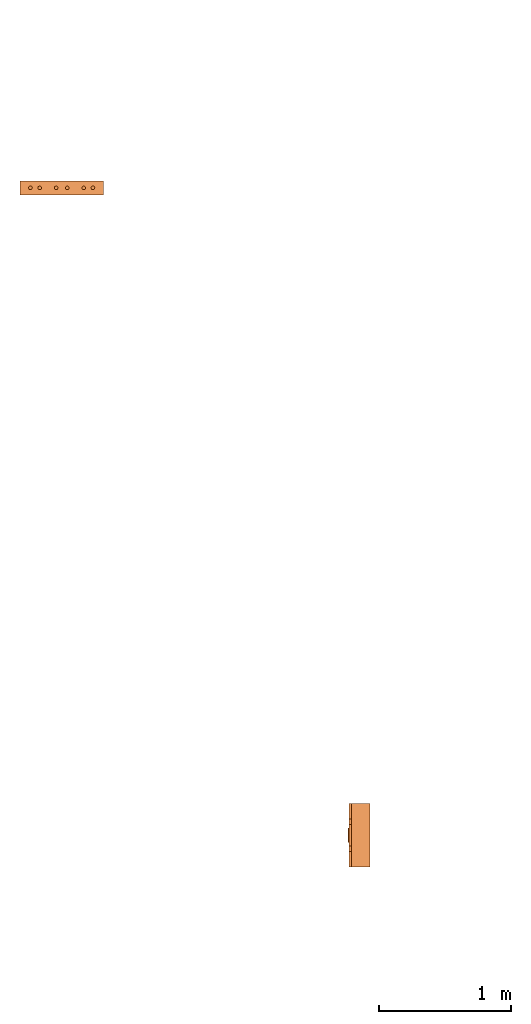
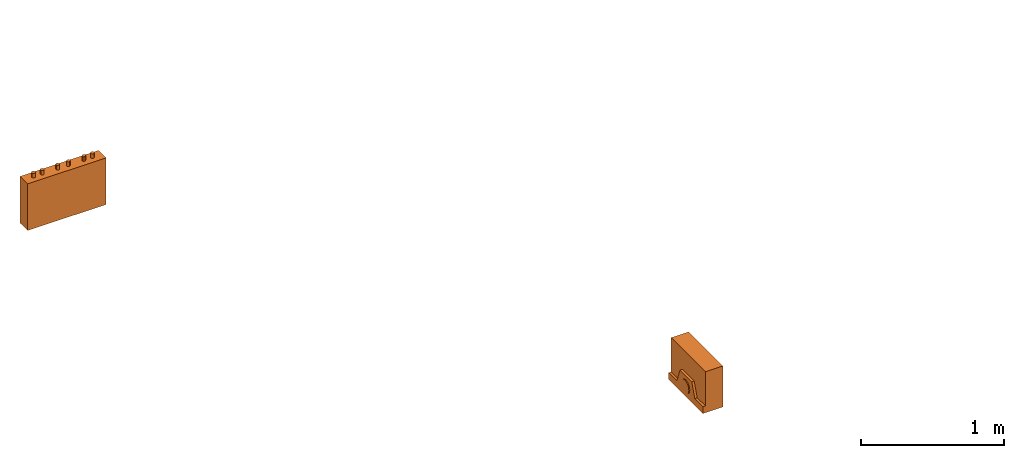
# One storey, part 1 of 3: 2 proxies.
"""IFC2X3 building model written with IfcOpenShell, lengths in millimetres."""

from ifc_helpers import new_model, entity, si_unit, converted_unit, derived_unit, direction, frame, origin, place, context, subcontext, project, spatial, faceted_brep, source, transform, mapped, material, material_list, type_object, type_shapes, element, save


model = new_model("IFC2X3")

# Units and contexts
model_context = context("Model", 3, precision=0.01, world=origin(), true_north=direction((6.12303176911189e-17, 1.0)))
body_context = subcontext(model_context, "Body", "Model", "MODEL_VIEW")
ifc_project = project(units=[si_unit("LENGTHUNIT", "METRE", prefix="MILLI"), si_unit("AREAUNIT", "SQUARE_METRE"), si_unit("VOLUMEUNIT", "CUBIC_METRE"), converted_unit("PLANEANGLEUNIT", "DEGREE", entity("IfcRatioMeasure", 0.0174532925199433), si_unit("PLANEANGLEUNIT", "RADIAN"), dimensions=[0, 0, 0, 0, 0, 0, 0]), si_unit("MASSUNIT", "GRAM", prefix="KILO"), derived_unit("MASSDENSITYUNIT", [(si_unit("MASSUNIT", "GRAM", prefix="KILO"), 1), (si_unit("LENGTHUNIT", "METRE"), -3)]), derived_unit("MOMENTOFINERTIAUNIT", [(si_unit("LENGTHUNIT", "METRE"), 4)]), si_unit("TIMEUNIT", "SECOND"), si_unit("FREQUENCYUNIT", "HERTZ"), si_unit("THERMODYNAMICTEMPERATUREUNIT", "DEGREE_CELSIUS"), derived_unit("THERMALTRANSMITTANCEUNIT", [(si_unit("MASSUNIT", "GRAM", prefix="KILO"), 1), (si_unit("THERMODYNAMICTEMPERATUREUNIT", "KELVIN"), -1), (si_unit("TIMEUNIT", "SECOND"), -3)]), derived_unit("VOLUMETRICFLOWRATEUNIT", [(si_unit("LENGTHUNIT", "METRE"), 3), (si_unit("TIMEUNIT", "SECOND"), -1)]), derived_unit("MASSFLOWRATEUNIT", [(si_unit("MASSUNIT", "GRAM", prefix="KILO"), 1), (si_unit("TIMEUNIT", "SECOND"), -1)]), derived_unit("ROTATIONALFREQUENCYUNIT", [(si_unit("TIMEUNIT", "SECOND"), -1)]), si_unit("ELECTRICCURRENTUNIT", "AMPERE"), si_unit("ELECTRICVOLTAGEUNIT", "VOLT"), si_unit("POWERUNIT", "WATT"), si_unit("FORCEUNIT", "NEWTON", prefix="KILO"), si_unit("ILLUMINANCEUNIT", "LUX"), si_unit("LUMINOUSFLUXUNIT", "LUMEN"), si_unit("LUMINOUSINTENSITYUNIT", "CANDELA"), derived_unit("USERDEFINED", [(si_unit("MASSUNIT", "GRAM", prefix="KILO"), -1), (si_unit("LENGTHUNIT", "METRE"), -2), (si_unit("TIMEUNIT", "SECOND"), 3), (si_unit("LUMINOUSFLUXUNIT", "LUMEN"), 1)]), derived_unit("LINEARVELOCITYUNIT", [(si_unit("LENGTHUNIT", "METRE"), 1), (si_unit("TIMEUNIT", "SECOND"), -1)]), si_unit("PRESSUREUNIT", "PASCAL"), derived_unit("USERDEFINED", [(si_unit("LENGTHUNIT", "METRE"), -2), (si_unit("MASSUNIT", "GRAM", prefix="KILO"), 1), (si_unit("TIMEUNIT", "SECOND"), -2)]), derived_unit("LINEARFORCEUNIT", [(si_unit("MASSUNIT", "GRAM", prefix="KILO"), 1), (si_unit("LENGTHUNIT", "METRE"), 1), (si_unit("TIMEUNIT", "SECOND"), -2), (si_unit("LENGTHUNIT", "METRE"), -1)]), derived_unit("PLANARFORCEUNIT", [(si_unit("MASSUNIT", "GRAM", prefix="KILO"), 1), (si_unit("LENGTHUNIT", "METRE"), 1), (si_unit("TIMEUNIT", "SECOND"), -2), (si_unit("LENGTHUNIT", "METRE"), -2)])], contexts=[model_context])

# Site, building, storey
site_placement = place(None, frame((0.0, 2493.83037508239, 0.0)))
site = spatial("IfcSite", under=ifc_project, at=site_placement, CompositionType="ELEMENT")
building_placement = place(site_placement, origin())
building = spatial("IfcBuilding", under=site, at=building_placement, CompositionType="ELEMENT")
storey_placement = place(building_placement, frame((0.0, 0.0, 12000.0)))
storey = spatial("IfcBuildingStorey", under=building, at=storey_placement, Name="04", CompositionType="ELEMENT", Elevation=12000.0)

# Proxies
ifc_material_1 = material()
ifc_material_2 = material()
ifc_material_list_1 = material_list([ifc_material_1, ifc_material_2])
building_element_proxy_type_1 = type_object("IfcBuildingElementProxyType", PredefinedType="NOTDEFINED", material=ifc_material_1)
shared_shape_1 = source(origin(), body_context, "Body", "Brep", [
    faceted_brep([(168.201612490282, 212.500000000001, 135.54049916809), (168.201612490282, 201.109127034741, 126.799974925206), (168.201612490282, 192.368602791857, 115.409101959946), (168.201612490282, 186.874079554102, 102.144149440585), (168.201612490282, 185.0, 87.9091019599461), (168.201612490282, 186.874079554102, 73.6740544793074), (168.201612490282, 192.368602791856, 60.4091019599461), (168.201612490282, 201.10912703474, 49.0182289946861), (168.201612490282, 212.500000000001, 40.2777047518019), (168.201612490282, 225.764952519362, 34.7831815140474), (168.201612490282, 240.0, 32.9091019599461), (168.201612490282, 254.235047480639, 34.7831815140472), (168.201612490282, 267.5, 40.2777047518019), (168.201612490282, 278.890872965261, 49.0182289946858), (168.201612490282, 287.631397208145, 60.4091019599458), (168.201612490282, 293.125920445899, 73.6740544793071), (168.201612490282, 295.0, 87.9091019599458), (168.201612490282, 293.125920445899, 102.144149440584), (168.201612490282, 287.631397208145, 115.409101959946), (168.201612490282, 278.890872965261, 126.799974925206), (168.201612490282, 267.500000000001, 135.54049916809), (168.201612490282, 254.235047480639, 141.035022405845), (168.201612490282, 240.0, 142.909101959946), (168.201612490282, 225.764952519362, 141.035022405845), (160.0, 225.764952519362, 34.7831815140474), (160.0, 212.500000000001, 40.2777047518019), (160.0, 201.10912703474, 49.0182289946861), (160.0, 192.368602791856, 60.4091019599461), (160.0, 186.874079554102, 73.6740544793074), (160.0, 185.0, 87.9091019599463), (160.0, 186.874079554102, 102.144149440585), (160.0, 192.368602791857, 115.409101959946), (160.0, 201.109127034741, 126.799974925206), (160.0, 212.500000000001, 135.54049916809), (160.0, 225.764952519362, 141.035022405845), (160.0, 240.0, 142.909101959946), (160.0, 254.235047480639, 141.035022405845), (160.0, 267.500000000001, 135.54049916809), (160.0, 278.890872965261, 126.799974925206), (160.0, 287.631397208145, 115.409101959946), (160.0, 293.125920445899, 102.144149440584), (160.0, 295.0, 87.9091019599458), (160.0, 293.125920445899, 73.6740544793071), (160.0, 287.631397208145, 60.4091019599458), (160.0, 278.890872965261, 49.0182289946858), (160.0, 267.5, 40.2777047518019), (160.0, 254.235047480639, 34.7831815140472), (160.0, 240.0, 32.9091019599461)], [[[0, 1, 2, 3, 4, 5, 6, 7, 8, 9, 10, 11, 12, 13, 14, 15, 16, 17, 18, 19, 20, 21, 22, 23]], [[24, 25, 26, 27, 28, 29, 30, 31, 32, 33, 34, 35, 36, 37, 38, 39, 40, 41, 42, 43, 44, 45, 46, 47]], [[40, 17, 16, 41]], [[39, 18, 17, 40]], [[20, 19, 38, 37]], [[39, 38, 19, 18]], [[21, 20, 37, 36]], [[22, 21, 36, 35]], [[34, 23, 22, 35]], [[33, 0, 23, 34]], [[2, 1, 32, 31]], [[33, 32, 1, 0]], [[3, 2, 31, 30]], [[4, 3, 30, 29]], [[28, 5, 4, 29]], [[27, 6, 5, 28]], [[8, 7, 26, 25]], [[27, 26, 7, 6]], [[9, 8, 25, 24]], [[10, 9, 24, 47]], [[46, 11, 10, 47]], [[45, 12, 11, 46]], [[14, 13, 44, 43]], [[45, 44, 13, 12]], [[15, 14, 43, 42]], [[16, 15, 42, 41]]]),
    faceted_brep([(160.0, 0.0, 0.0), (160.0, 480.0, 0.0), (160.0, 480.0, 58.2870579365997), (160.0, 365.0, 58.2870579366005), (160.0, 322.247482084292, 175.748635534839), (160.0, 157.75251791571, 175.748635534839), (160.0, 115.0, 58.2870579366), (160.0, 0.0, 58.2870579365997), (0.0, 480.0, 0.0), (0.0, 0.0, 0.0), (0.0, 0.0, 350.0), (0.0, 480.0, 350.0), (140.211167148102, 480.0, 350.0), (140.211167148102, 480.0, 58.2870579365997), (140.211167148102, 0.0, 350.0), (140.211167148102, 0.0, 58.2870579365997), (140.211167148102, 365.0, 58.2870579366), (140.211167148102, 115.0, 58.2870579366), (140.211167148102, 157.75251791571, 175.748635534839), (140.211167148102, 322.247482084292, 175.748635534839)], [[[0, 1, 2, 3, 4, 5, 6, 7]], [[8, 9, 10, 11]], [[8, 11, 12, 13, 2, 1]], [[11, 10, 14, 12]], [[10, 9, 0, 7, 15, 14]], [[1, 0, 9, 8]], [[16, 13, 12, 14, 15, 17, 18, 19]], [[13, 16, 3, 2]], [[17, 15, 7, 6]], [[18, 17, 6, 5]], [[19, 18, 5, 4]], [[16, 19, 4, 3]]]),
])
type_shapes(building_element_proxy_type_1, [shared_shape_1])
proxy_1_placement = place(storey_placement, frame((21107.6085349596, 787.095767178686, 1500.0), z_axis=(0.0, 0.0, 1.0), x_axis=(-1.0, 0.0, 0.0)))
element("IfcBuildingElementProxy", 1, at=proxy_1_placement, inside=storey, type_object=building_element_proxy_type_1, material=ifc_material_list_1, context=body_context, shape_type="MappedRepresentation", body=[
    mapped(shared_shape_1, transform((0.0, 0.0, 0.0), scale=1.0)),
])
ifc_material_3 = material()
ifc_material_list_2 = material_list([ifc_material_3, ifc_material_2])
building_element_proxy_type_2 = type_object("IfcBuildingElementProxyType", PredefinedType="NOTDEFINED", material=ifc_material_3)
shared_shape_2 = source(origin(), body_context, "Body", "Brep", [
    faceted_brep([(61.7366777047886, 89.258069163288, 398.0), (63.9615384211591, 86.3585742266764, 398.0), (65.3601443362239, 82.9820408581116, 398.0), (65.837182768177, 79.3585742266763, 398.0), (65.3601443362239, 75.735107595241, 398.0), (63.9615384211591, 72.3585742266763, 398.0), (61.7366777047886, 69.4590792900646, 398.0), (58.8371827681769, 67.2342185736942, 398.0), (55.4606493996122, 65.8356126586294, 398.0), (51.8371827681769, 65.3585742266764, 398.0), (48.2137161367416, 65.8356126586295, 398.0), (44.8371827681769, 67.2342185736943, 398.0), (41.9376878315653, 69.4590792900647, 398.0), (39.7128271151948, 72.3585742266764, 398.0), (38.31422120013, 75.7351075952411, 398.0), (37.837182768177, 79.3585742266764, 398.0), (38.31422120013, 82.9820408581117, 398.0), (39.7128271151949, 86.3585742266764, 398.0), (41.9376878315653, 89.258069163288, 398.0), (44.837182768177, 91.4829298796585, 398.0), (48.2137161367417, 92.8815357947233, 398.0), (51.837182768177, 93.3585742266764, 398.0), (55.4606493996123, 92.8815357947233, 398.0), (58.837182768177, 91.4829298796585, 398.0), (58.8371827681769, 67.2342185736942, 436.716690815491), (61.7366777047886, 69.4590792900646, 436.716690815491), (63.9615384211591, 72.3585742266763, 436.716690815491), (65.3601443362239, 75.735107595241, 436.716690815491), (65.837182768177, 79.3585742266764, 436.716690815491), (65.3601443362239, 82.9820408581116, 436.716690815491), (63.9615384211591, 86.3585742266764, 436.716690815491), (61.7366777047886, 89.258069163288, 436.716690815491), (58.837182768177, 91.4829298796585, 436.716690815491), (55.4606493996123, 92.8815357947233, 436.716690815491), (51.837182768177, 93.3585742266764, 436.716690815491), (48.2137161367417, 92.8815357947233, 436.716690815491), (44.837182768177, 91.4829298796585, 436.716690815491), (41.9376878315653, 89.258069163288, 436.716690815491), (39.7128271151949, 86.3585742266764, 436.716690815491), (38.31422120013, 82.9820408581117, 436.716690815491), (37.837182768177, 79.3585742266764, 436.716690815491), (38.31422120013, 75.7351075952411, 436.716690815491), (39.7128271151948, 72.3585742266764, 436.716690815491), (41.9376878315653, 69.4590792900647, 436.716690815491), (44.8371827681769, 67.2342185736943, 436.716690815491), (48.2137161367416, 65.8356126586295, 436.716690815491), (51.8371827681769, 65.3585742266764, 436.716690815491), (55.4606493996122, 65.8356126586294, 436.716690815491)], [[[0, 1, 2, 3, 4, 5, 6, 7, 8, 9, 10, 11, 12, 13, 14, 15, 16, 17, 18, 19, 20, 21, 22, 23]], [[24, 25, 26, 27, 28, 29, 30, 31, 32, 33, 34, 35, 36, 37, 38, 39, 40, 41, 42, 43, 44, 45, 46, 47]], [[40, 15, 14, 41]], [[13, 42, 41, 14]], [[43, 12, 11, 44]], [[13, 12, 43, 42]], [[44, 11, 10, 45]], [[9, 46, 45, 10]], [[47, 8, 7, 24]], [[6, 25, 24, 7]], [[26, 5, 4, 27]], [[6, 5, 26, 25]], [[27, 4, 3, 28]], [[47, 46, 9, 8]], [[1, 30, 29, 2]], [[0, 31, 30, 1]], [[22, 33, 32, 23]], [[23, 32, 31, 0]], [[21, 34, 33, 22]], [[28, 3, 2, 29]], [[35, 20, 19, 36]], [[18, 37, 36, 19]], [[38, 17, 16, 39]], [[18, 17, 38, 37]], [[39, 16, 15, 40]], [[35, 34, 21, 20]]]),
    faceted_brep([(58.837182768177, 542.517070120343, 436.716690815491), (61.7366777047886, 544.741930836713, 436.716690815491), (63.9615384211591, 547.641425773325, 436.716690815491), (65.360144336224, 551.017959141889, 436.716690815491), (65.837182768177, 554.641425773325, 436.716690815491), (65.360144336224, 558.26489240476, 436.716690815491), (63.9615384211592, 561.641425773325, 436.716690815491), (61.7366777047887, 564.540920709937, 436.716690815491), (58.8371827681771, 566.765781426307, 436.716690815491), (55.4606493996123, 568.164387341372, 436.716690815491), (51.8371827681771, 568.641425773325, 436.716690815491), (48.2137161367418, 568.164387341372, 436.716690815491), (44.8371827681771, 566.765781426307, 436.716690815491), (41.9376878315654, 564.540920709937, 436.716690815491), (39.7128271151949, 561.641425773325, 436.716690815491), (38.3142212001301, 558.26489240476, 436.716690815491), (37.837182768177, 554.641425773325, 436.716690815491), (38.3142212001301, 551.01795914189, 436.716690815491), (39.7128271151949, 547.641425773325, 436.716690815491), (41.9376878315653, 544.741930836713, 436.716690815491), (44.837182768177, 542.517070120343, 436.716690815491), (48.2137161367417, 541.118464205278, 436.716690815491), (51.837182768177, 540.641425773325, 436.716690815491), (55.4606493996123, 541.118464205278, 436.716690815491), (51.8371827681771, 568.641425773325, 398.0), (55.4606493996123, 568.164387341372, 398.0), (58.8371827681771, 566.765781426307, 398.0), (61.7366777047887, 564.540920709937, 398.0), (63.9615384211592, 561.641425773325, 398.0), (65.360144336224, 558.26489240476, 398.0), (65.837182768177, 554.641425773325, 398.0), (65.360144336224, 551.017959141889, 398.0), (63.9615384211591, 547.641425773325, 398.0), (61.7366777047886, 544.741930836713, 398.0), (58.837182768177, 542.517070120343, 398.0), (55.4606493996123, 541.118464205278, 398.0), (51.837182768177, 540.641425773325, 398.0), (48.2137161367417, 541.118464205278, 398.0), (44.837182768177, 542.517070120343, 398.0), (41.9376878315653, 544.741930836713, 398.0), (39.7128271151949, 547.641425773325, 398.0), (38.3142212001301, 551.01795914189, 398.0), (37.837182768177, 554.641425773325, 398.0), (38.3142212001301, 558.26489240476, 398.0), (39.7128271151949, 561.641425773325, 398.0), (41.9376878315654, 564.540920709937, 398.0), (44.8371827681771, 566.765781426307, 398.0), (48.2137161367418, 568.164387341372, 398.0)], [[[0, 1, 2, 3, 4, 5, 6, 7, 8, 9, 10, 11, 12, 13, 14, 15, 16, 17, 18, 19, 20, 21, 22, 23]], [[24, 25, 26, 27, 28, 29, 30, 31, 32, 33, 34, 35, 36, 37, 38, 39, 40, 41, 42, 43, 44, 45, 46, 47]], [[17, 41, 40, 18]], [[39, 19, 18, 40]], [[20, 38, 37, 21]], [[39, 38, 20, 19]], [[21, 37, 36, 22]], [[41, 17, 16, 42]], [[23, 35, 34, 0]], [[33, 1, 0, 34]], [[2, 32, 31, 3]], [[33, 32, 2, 1]], [[3, 31, 30, 4]], [[35, 23, 22, 36]], [[29, 5, 4, 30]], [[28, 6, 5, 29]], [[9, 25, 24, 10]], [[27, 7, 6, 28]], [[26, 8, 7, 27]], [[26, 25, 9, 8]], [[11, 47, 46, 12]], [[45, 13, 12, 46]], [[14, 44, 43, 15]], [[45, 44, 14, 13]], [[15, 43, 42, 16]], [[47, 11, 10, 24]]]),
    faceted_brep([(58.8371827681769, 472.517070120343, 436.716690815491), (61.7366777047886, 474.741930836713, 436.716690815491), (63.961538421159, 477.641425773325, 436.716690815491), (65.3601443362239, 481.017959141889, 436.716690815491), (65.8371827681769, 484.641425773325, 436.716690815491), (65.3601443362239, 488.26489240476, 436.716690815491), (63.9615384211591, 491.641425773325, 436.716690815491), (61.7366777047886, 494.540920709936, 436.716690815491), (58.837182768177, 496.765781426307, 436.716690815491), (55.4606493996123, 498.164387341372, 436.716690815491), (51.837182768177, 498.641425773325, 436.716690815491), (48.2137161367417, 498.164387341372, 436.716690815491), (44.837182768177, 496.765781426307, 436.716690815491), (41.9376878315653, 494.540920709937, 436.716690815491), (39.7128271151948, 491.641425773325, 436.716690815491), (38.31422120013, 488.26489240476, 436.716690815491), (37.837182768177, 484.641425773325, 436.716690815491), (38.31422120013, 481.01795914189, 436.716690815491), (39.7128271151948, 477.641425773325, 436.716690815491), (41.9376878315653, 474.741930836713, 436.716690815491), (44.8371827681769, 472.517070120343, 436.716690815491), (48.2137161367416, 471.118464205278, 436.716690815491), (51.8371827681769, 470.641425773325, 436.716690815491), (55.4606493996122, 471.118464205278, 436.716690815491), (51.837182768177, 498.641425773325, 398.0), (55.4606493996123, 498.164387341372, 398.0), (58.837182768177, 496.765781426307, 398.0), (61.7366777047886, 494.540920709936, 398.0), (63.9615384211591, 491.641425773325, 398.0), (65.3601443362239, 488.26489240476, 398.0), (65.8371827681769, 484.641425773325, 398.0), (65.3601443362239, 481.017959141889, 398.0), (63.961538421159, 477.641425773325, 398.0), (61.7366777047886, 474.741930836713, 398.0), (58.8371827681769, 472.517070120343, 398.0), (55.4606493996122, 471.118464205278, 398.0), (51.8371827681769, 470.641425773325, 398.0), (48.2137161367416, 471.118464205278, 398.0), (44.8371827681769, 472.517070120343, 398.0), (41.9376878315653, 474.741930836713, 398.0), (39.7128271151948, 477.641425773325, 398.0), (38.31422120013, 481.01795914189, 398.0), (37.837182768177, 484.641425773325, 398.0), (38.31422120013, 488.26489240476, 398.0), (39.7128271151948, 491.641425773325, 398.0), (41.9376878315653, 494.540920709937, 398.0), (44.837182768177, 496.765781426307, 398.0), (48.2137161367417, 498.164387341372, 398.0)], [[[0, 1, 2, 3, 4, 5, 6, 7, 8, 9, 10, 11, 12, 13, 14, 15, 16, 17, 18, 19, 20, 21, 22, 23]], [[24, 25, 26, 27, 28, 29, 30, 31, 32, 33, 34, 35, 36, 37, 38, 39, 40, 41, 42, 43, 44, 45, 46, 47]], [[16, 42, 41, 17]], [[40, 18, 17, 41]], [[19, 39, 38, 20]], [[40, 39, 19, 18]], [[20, 38, 37, 21]], [[36, 22, 21, 37]], [[23, 35, 34, 0]], [[33, 1, 0, 34]], [[2, 32, 31, 3]], [[33, 32, 2, 1]], [[3, 31, 30, 4]], [[23, 22, 36, 35]], [[28, 6, 5, 29]], [[27, 7, 6, 28]], [[25, 9, 8, 26]], [[26, 8, 7, 27]], [[24, 10, 9, 25]], [[4, 30, 29, 5]], [[11, 47, 46, 12]], [[45, 13, 12, 46]], [[14, 44, 43, 15]], [[45, 44, 14, 13]], [[15, 43, 42, 16]], [[11, 10, 24, 47]]]),
    faceted_brep([(58.8371827681766, 347.517070120343, 436.716690815491), (61.7366777047883, 349.741930836713, 436.716690815491), (63.9615384211588, 352.641425773325, 436.716690815491), (65.3601443362236, 356.017959141889, 436.716690815491), (65.8371827681767, 359.641425773325, 436.716690815491), (65.3601443362237, 363.26489240476, 436.716690815491), (63.9615384211589, 366.641425773325, 436.716690815491), (61.7366777047884, 369.540920709937, 436.716690815491), (58.8371827681767, 371.765781426307, 436.716690815491), (55.460649399612, 373.164387341372, 436.716690815491), (51.8371827681767, 373.641425773325, 436.716690815491), (48.2137161367414, 373.164387341372, 436.716690815491), (44.8371827681767, 371.765781426307, 436.716690815491), (41.9376878315651, 369.540920709937, 436.716690815491), (39.7128271151946, 366.641425773325, 436.716690815491), (38.3142212001298, 363.26489240476, 436.716690815491), (37.8371827681767, 359.641425773325, 436.716690815491), (38.3142212001298, 356.01795914189, 436.716690815491), (39.7128271151945, 352.641425773325, 436.716690815491), (41.937687831565, 349.741930836713, 436.716690815491), (44.8371827681767, 347.517070120343, 436.716690815491), (48.2137161367414, 346.118464205278, 436.716690815491), (51.8371827681766, 345.641425773325, 436.716690815491), (55.4606493996119, 346.118464205278, 436.716690815491), (51.8371827681767, 373.641425773325, 398.0), (55.460649399612, 373.164387341372, 398.0), (58.8371827681767, 371.765781426307, 398.0), (61.7366777047884, 369.540920709937, 398.0), (63.9615384211589, 366.641425773325, 398.0), (65.3601443362237, 363.26489240476, 398.0), (65.8371827681767, 359.641425773325, 398.0), (65.3601443362236, 356.017959141889, 398.0), (63.9615384211588, 352.641425773325, 398.0), (61.7366777047883, 349.741930836713, 398.0), (58.8371827681766, 347.517070120343, 398.0), (55.4606493996119, 346.118464205278, 398.0), (51.8371827681766, 345.641425773325, 398.0), (48.2137161367414, 346.118464205278, 398.0), (44.8371827681767, 347.517070120343, 398.0), (41.937687831565, 349.741930836713, 398.0), (39.7128271151945, 352.641425773325, 398.0), (38.3142212001298, 356.01795914189, 398.0), (37.8371827681767, 359.641425773325, 398.0), (38.3142212001298, 363.26489240476, 398.0), (39.7128271151946, 366.641425773325, 398.0), (41.9376878315651, 369.540920709937, 398.0), (44.8371827681767, 371.765781426307, 398.0), (48.2137161367414, 373.164387341372, 398.0)], [[[0, 1, 2, 3, 4, 5, 6, 7, 8, 9, 10, 11, 12, 13, 14, 15, 16, 17, 18, 19, 20, 21, 22, 23]], [[24, 25, 26, 27, 28, 29, 30, 31, 32, 33, 34, 35, 36, 37, 38, 39, 40, 41, 42, 43, 44, 45, 46, 47]], [[16, 42, 41, 17]], [[40, 18, 17, 41]], [[19, 39, 38, 20]], [[40, 39, 19, 18]], [[20, 38, 37, 21]], [[36, 22, 21, 37]], [[23, 35, 34, 0]], [[33, 1, 0, 34]], [[2, 32, 31, 3]], [[33, 32, 2, 1]], [[3, 31, 30, 4]], [[23, 22, 36, 35]], [[28, 6, 5, 29]], [[27, 7, 6, 28]], [[25, 9, 8, 26]], [[26, 8, 7, 27]], [[24, 10, 9, 25]], [[4, 30, 29, 5]], [[11, 47, 46, 12]], [[45, 13, 12, 46]], [[14, 44, 43, 15]], [[45, 44, 14, 13]], [[15, 43, 42, 16]], [[11, 10, 24, 47]]]),
    faceted_brep([(58.8371827681766, 262.234218573694, 436.716690815491), (61.7366777047883, 264.459079290065, 436.716690815491), (63.9615384211588, 267.358574226676, 436.716690815491), (65.3601443362236, 270.735107595241, 436.716690815491), (65.8371827681767, 274.358574226676, 436.716690815491), (65.3601443362237, 277.982040858112, 436.716690815491), (63.9615384211588, 281.358574226676, 436.716690815491), (61.7366777047884, 284.258069163288, 436.716690815491), (58.8371827681767, 286.482929879658, 436.716690815491), (55.460649399612, 287.881535794723, 436.716690815491), (51.8371827681767, 288.358574226676, 436.716690815491), (48.2137161367414, 287.881535794723, 436.716690815491), (44.8371827681767, 286.482929879659, 436.716690815491), (41.9376878315651, 284.258069163288, 436.716690815491), (39.7128271151946, 281.358574226676, 436.716690815491), (38.3142212001298, 277.982040858112, 436.716690815491), (37.8371827681767, 274.358574226676, 436.716690815491), (38.3142212001297, 270.735107595241, 436.716690815491), (39.7128271151945, 267.358574226676, 436.716690815491), (41.937687831565, 264.459079290065, 436.716690815491), (44.8371827681767, 262.234218573694, 436.716690815491), (48.2137161367414, 260.835612658629, 436.716690815491), (51.8371827681766, 260.358574226676, 436.716690815491), (55.4606493996119, 260.835612658629, 436.716690815491), (51.8371827681767, 288.358574226676, 398.0), (55.460649399612, 287.881535794723, 398.0), (58.8371827681767, 286.482929879658, 398.0), (61.7366777047884, 284.258069163288, 398.0), (63.9615384211588, 281.358574226676, 398.0), (65.3601443362237, 277.982040858112, 398.0), (65.8371827681767, 274.358574226676, 398.0), (65.3601443362236, 270.735107595241, 398.0), (63.9615384211588, 267.358574226676, 398.0), (61.7366777047883, 264.459079290065, 398.0), (58.8371827681766, 262.234218573694, 398.0), (55.4606493996119, 260.835612658629, 398.0), (51.8371827681766, 260.358574226676, 398.0), (48.2137161367414, 260.835612658629, 398.0), (44.8371827681767, 262.234218573694, 398.0), (41.937687831565, 264.459079290065, 398.0), (39.7128271151945, 267.358574226676, 398.0), (38.3142212001297, 270.735107595241, 398.0), (37.8371827681767, 274.358574226676, 398.0), (38.3142212001298, 277.982040858112, 398.0), (39.7128271151946, 281.358574226676, 398.0), (41.9376878315651, 284.258069163288, 398.0), (44.8371827681767, 286.482929879659, 398.0), (48.2137161367414, 287.881535794723, 398.0)], [[[0, 1, 2, 3, 4, 5, 6, 7, 8, 9, 10, 11, 12, 13, 14, 15, 16, 17, 18, 19, 20, 21, 22, 23]], [[24, 25, 26, 27, 28, 29, 30, 31, 32, 33, 34, 35, 36, 37, 38, 39, 40, 41, 42, 43, 44, 45, 46, 47]], [[16, 42, 41, 17]], [[40, 18, 17, 41]], [[19, 39, 38, 20]], [[40, 39, 19, 18]], [[20, 38, 37, 21]], [[36, 22, 21, 37]], [[23, 35, 34, 0]], [[33, 1, 0, 34]], [[2, 32, 31, 3]], [[33, 32, 2, 1]], [[3, 31, 30, 4]], [[23, 22, 36, 35]], [[4, 30, 29, 5]], [[28, 6, 5, 29]], [[7, 27, 26, 8]], [[28, 27, 7, 6]], [[8, 26, 25, 9]], [[24, 10, 9, 25]], [[11, 47, 46, 12]], [[45, 13, 12, 46]], [[14, 44, 43, 15]], [[45, 44, 14, 13]], [[15, 43, 42, 16]], [[11, 10, 24, 47]]]),
    faceted_brep([(58.8371827681768, 137.234218573694, 436.716690815491), (61.7366777047885, 139.459079290065, 436.716690815491), (63.961538421159, 142.358574226676, 436.716690815491), (65.3601443362238, 145.735107595241, 436.716690815491), (65.8371827681769, 149.358574226676, 436.716690815491), (65.3601443362239, 152.982040858112, 436.716690815491), (63.961538421159, 156.358574226676, 436.716690815491), (61.7366777047886, 159.258069163288, 436.716690815491), (58.8371827681769, 161.482929879659, 436.716690815491), (55.4606493996122, 162.881535794723, 436.716690815491), (51.8371827681769, 163.358574226676, 436.716690815491), (48.2137161367416, 162.881535794723, 436.716690815491), (44.8371827681769, 161.482929879659, 436.716690815491), (41.9376878315653, 159.258069163288, 436.716690815491), (39.7128271151948, 156.358574226676, 436.716690815491), (38.31422120013, 152.982040858112, 436.716690815491), (37.8371827681769, 149.358574226676, 436.716690815491), (38.3142212001299, 145.735107595241, 436.716690815491), (39.7128271151947, 142.358574226676, 436.716690815491), (41.9376878315652, 139.459079290065, 436.716690815491), (44.8371827681769, 137.234218573694, 436.716690815491), (48.2137161367416, 135.83561265863, 436.716690815491), (51.8371827681768, 135.358574226676, 436.716690815491), (55.4606493996121, 135.835612658629, 436.716690815491), (61.7366777047886, 159.258069163288, 398.0), (63.961538421159, 156.358574226676, 398.0), (65.3601443362239, 152.982040858112, 398.0), (65.8371827681769, 149.358574226676, 398.0), (65.3601443362238, 145.735107595241, 398.0), (63.961538421159, 142.358574226676, 398.0), (61.7366777047885, 139.459079290065, 398.0), (58.8371827681768, 137.234218573694, 398.0), (55.4606493996121, 135.835612658629, 398.0), (51.8371827681768, 135.358574226676, 398.0), (48.2137161367416, 135.83561265863, 398.0), (44.8371827681769, 137.234218573694, 398.0), (41.9376878315652, 139.459079290065, 398.0), (39.7128271151947, 142.358574226676, 398.0), (38.3142212001299, 145.735107595241, 398.0), (37.8371827681769, 149.358574226676, 398.0), (38.31422120013, 152.982040858112, 398.0), (39.7128271151948, 156.358574226676, 398.0), (41.9376878315653, 159.258069163288, 398.0), (44.8371827681769, 161.482929879659, 398.0), (48.2137161367416, 162.881535794723, 398.0), (51.8371827681769, 163.358574226676, 398.0), (55.4606493996122, 162.881535794723, 398.0), (58.8371827681769, 161.482929879659, 398.0)], [[[0, 1, 2, 3, 4, 5, 6, 7, 8, 9, 10, 11, 12, 13, 14, 15, 16, 17, 18, 19, 20, 21, 22, 23]], [[24, 25, 26, 27, 28, 29, 30, 31, 32, 33, 34, 35, 36, 37, 38, 39, 40, 41, 42, 43, 44, 45, 46, 47]], [[16, 39, 38, 17]], [[37, 18, 17, 38]], [[19, 36, 35, 20]], [[37, 36, 19, 18]], [[20, 35, 34, 21]], [[33, 22, 21, 34]], [[23, 32, 31, 0]], [[30, 1, 0, 31]], [[2, 29, 28, 3]], [[30, 29, 2, 1]], [[3, 28, 27, 4]], [[23, 22, 33, 32]], [[25, 6, 5, 26]], [[24, 7, 6, 25]], [[46, 9, 8, 47]], [[47, 8, 7, 24]], [[45, 10, 9, 46]], [[4, 27, 26, 5]], [[11, 44, 43, 12]], [[42, 13, 12, 43]], [[14, 41, 40, 15]], [[42, 41, 14, 13]], [[15, 40, 39, 16]], [[11, 10, 45, 44]]]),
    faceted_brep([(106.0, 0.0, 0.0), (106.0, 634.0, 0.0), (106.0, 634.0, 398.0), (106.0, 0.0, 398.0), (0.0, 634.0, 398.0), (0.0, 524.500000000001, 254.822902819641), (0.0, 518.470476127564, 257.320413382257), (0.0, 529.677669529664, 250.849937254693), (0.0, 512.0, 258.17226772503), (0.0, 122.0, 258.17226772503), (0.0, 533.650635094612, 245.672267725029), (0.0, 536.148145657227, 239.642743852593), (0.0, 537.0, 233.17226772503), (0.0, 634.0, 0.0), (0.0, 0.0, 398.0), (0.0, 537.0, 143.17226772503), (0.0, 536.148145657227, 136.701791597467), (0.0, 533.650635094611, 130.67226772503), (0.0, 529.677669529664, 125.494598195366), (0.0, 524.5, 121.521632630419), (0.0, 518.470476127563, 119.024122067803), (0.0, 512.0, 118.17226772503), (0.0, 122.0, 118.172267725031), (0.0, 0.0, 0.0), (0.0, 97.0, 233.17226772503), (0.0, 115.529523872437, 119.024122067805), (0.0, 109.5, 121.521632630421), (0.0, 104.322330470337, 125.494598195368), (0.0, 100.349364905389, 130.672267725032), (0.0, 97.8518543427736, 136.701791597469), (0.0, 97.0, 143.172267725033), (0.0, 97.8518543427739, 239.642743852593), (0.0, 115.529523872438, 257.320413382257), (0.0, 109.500000000001, 254.822902819641), (0.0, 104.322330470337, 250.849937254693), (0.0, 100.34936490539, 245.67226772503), (16.2395209800454, 533.650635094612, 245.672267725029), (16.2395209800454, 536.148145657227, 239.642743852593), (16.2395209800454, 537.0, 233.17226772503), (16.2395209800454, 537.0, 143.17226772503), (16.2395209800454, 536.148145657227, 136.701791597467), (16.2395209800454, 533.650635094611, 130.67226772503), (16.2395209800454, 529.677669529664, 125.494598195366), (16.2395209800454, 524.5, 121.521632630419), (16.2395209800454, 518.470476127563, 119.024122067803), (16.2395209800454, 512.0, 118.17226772503), (16.2395209800454, 122.0, 118.172267725032), (16.2395209800454, 115.529523872437, 119.024122067805), (16.2395209800454, 109.5, 121.521632630421), (16.2395209800454, 104.322330470337, 125.494598195368), (16.2395209800454, 100.349364905389, 130.672267725032), (16.2395209800454, 97.8518543427736, 136.701791597469), (16.2395209800454, 97.0, 143.172267725032), (16.2395209800454, 97.0, 233.17226772503), (16.2395209800454, 97.8518543427739, 239.642743852593), (16.2395209800454, 100.34936490539, 245.67226772503), (16.2395209800454, 104.322330470337, 250.849937254694), (16.2395209800454, 109.500000000001, 254.822902819641), (16.2395209800454, 115.529523872438, 257.320413382257), (16.2395209800454, 122.0, 258.17226772503), (16.2395209800454, 512.0, 258.17226772503), (16.2395209800454, 518.470476127564, 257.320413382257), (16.2395209800454, 524.500000000001, 254.822902819641), (16.2395209800454, 529.677669529664, 250.849937254693)], [[[0, 1, 2, 3]], [[4, 5, 6]], [[5, 4, 7]], [[6, 8, 4]], [[4, 8, 9]], [[10, 7, 4]], [[11, 10, 4]], [[12, 11, 4]], [[4, 13, 12]], [[9, 14, 4]], [[15, 12, 13]], [[16, 15, 13]], [[16, 13, 17]], [[18, 17, 13]], [[13, 19, 18]], [[19, 13, 20]], [[21, 20, 13]], [[13, 22, 21]], [[22, 13, 23]], [[14, 24, 23]], [[25, 22, 23]], [[23, 26, 25]], [[26, 23, 27]], [[28, 27, 23]], [[28, 23, 29]], [[30, 29, 23]], [[30, 23, 24]], [[31, 24, 14]], [[9, 32, 14]], [[33, 14, 32]], [[14, 33, 34]], [[34, 35, 14]], [[35, 31, 14]], [[2, 1, 13, 4]], [[3, 2, 4, 14]], [[0, 3, 14, 23]], [[1, 0, 23, 13]], [[36, 37, 38, 39, 40, 41, 42, 43, 44, 45, 46, 47, 48, 49, 50, 51, 52, 53, 54, 55, 56, 57, 58, 59, 60, 61, 62, 63]], [[9, 8, 60, 59]], [[32, 9, 59, 58]], [[33, 32, 58, 57]], [[33, 57, 56, 34]], [[35, 34, 56, 55]], [[31, 35, 55, 54]], [[31, 54, 53, 24]], [[24, 53, 52, 30]], [[29, 30, 52, 51]], [[28, 29, 51, 50]], [[28, 50, 49, 27]], [[26, 27, 49, 48]], [[25, 26, 48, 47]], [[25, 47, 46, 22]], [[22, 46, 45, 21]], [[20, 21, 45, 44]], [[19, 20, 44, 43]], [[19, 43, 42, 18]], [[17, 18, 42, 41]], [[16, 17, 41, 40]], [[16, 40, 39, 15]], [[15, 39, 38, 12]], [[11, 12, 38, 37]], [[10, 11, 37, 36]], [[10, 36, 63, 7]], [[5, 7, 63, 62]], [[6, 5, 62, 61]], [[6, 61, 60, 8]]]),
])
type_shapes(building_element_proxy_type_2, [shared_shape_2])
proxy_2_placement = place(storey_placement, frame((18446.0993048122, 5521.31843157248, 840.0), z_axis=(0.0, 0.0, 1.0), x_axis=(0.0, -1.0, 0.0)))
element("IfcBuildingElementProxy", 2, at=proxy_2_placement, inside=storey, type_object=building_element_proxy_type_2, material=ifc_material_list_2, context=body_context, shape_type="MappedRepresentation", body=[
    mapped(shared_shape_2, transform((0.0, 0.0, 0.0), scale=1.0)),
])

save(model, "model.ifc")
